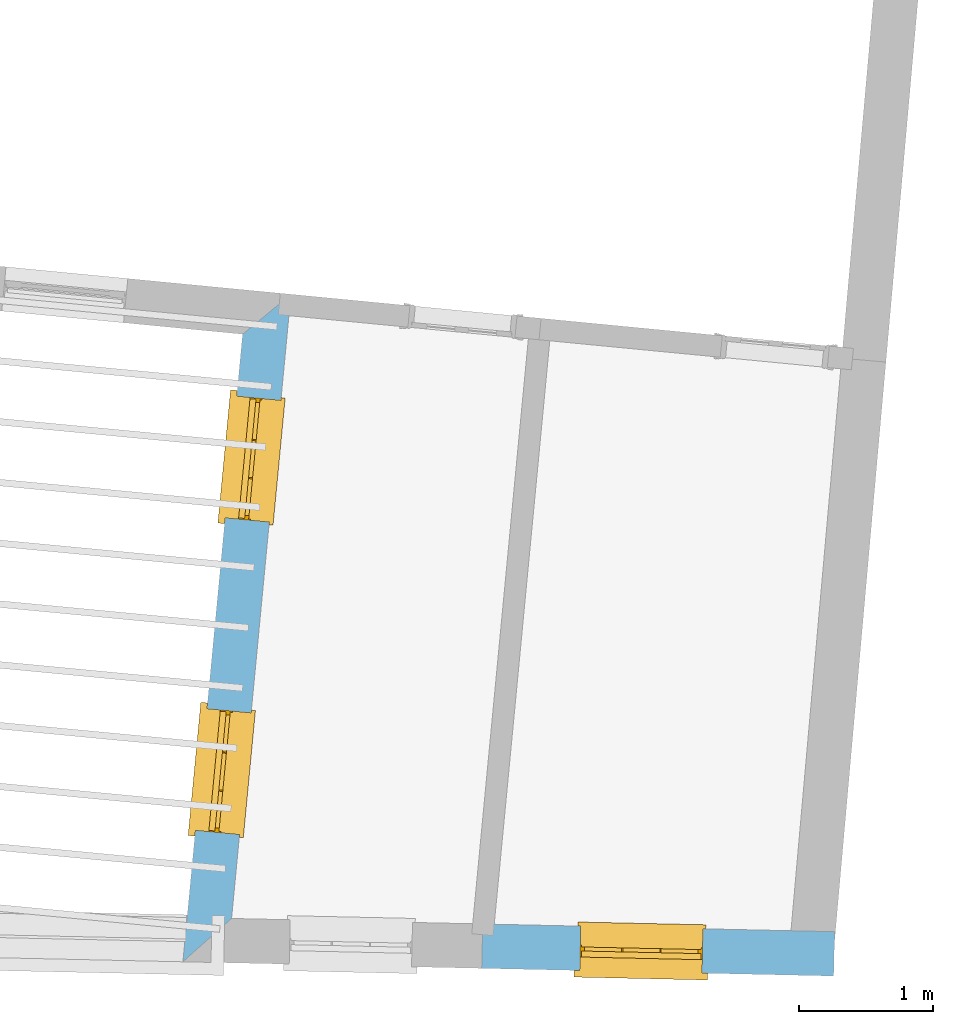
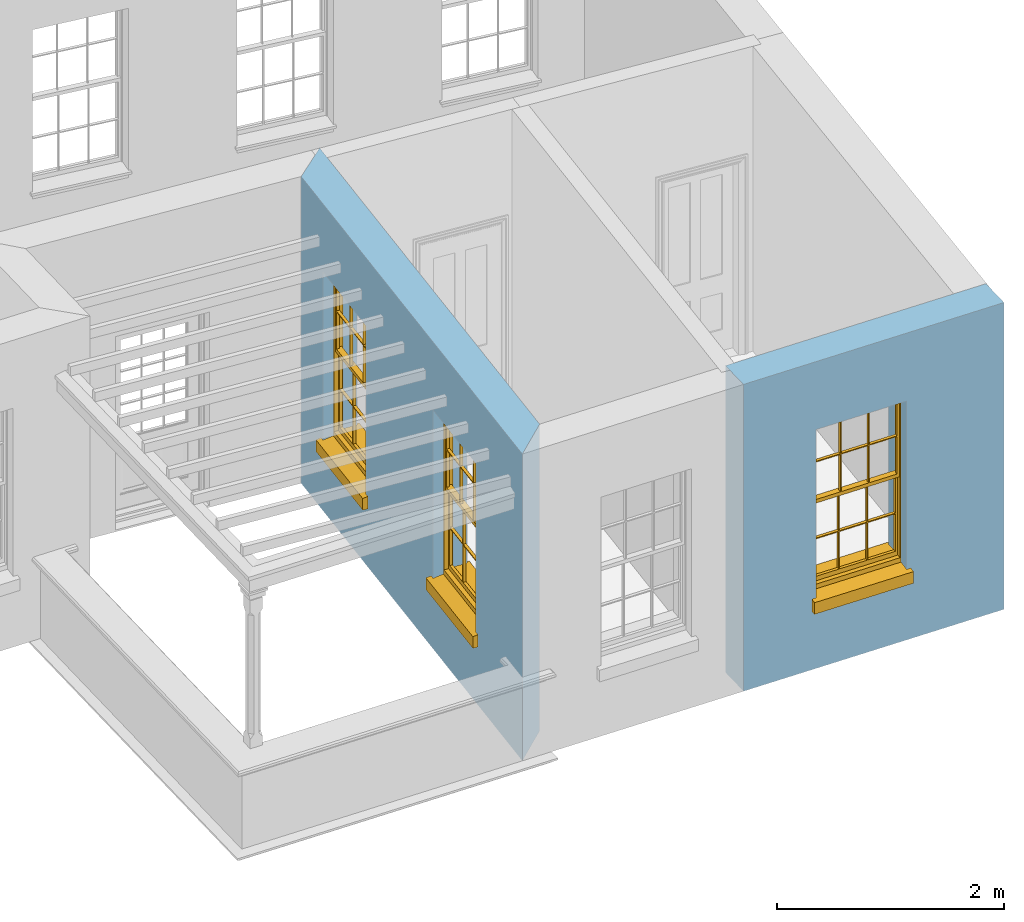
# One storey, part 5 of 12: 3 windows, 3 openings, plus 2 elements that do not belong to this part.
"""IFC2X3 building model written with IfcOpenShell, lengths in metres."""

from ifc_helpers import new_model, si_unit, frame, origin, place, context, subcontext, project, spatial, polyline, outline, extrude, faceted_brep, material, layer, layer_set, layer_usage, element, fill, save


model = new_model("IFC2X3")

# Units and contexts
model_context = context("Model", 3, world=origin())
body_context = subcontext(model_context, "Body", "Model", "MODEL_VIEW")
ifc_project = project(units=[si_unit("PLANEANGLEUNIT", "RADIAN"), si_unit("MASSUNIT", "GRAM", prefix="KILO"), si_unit("FORCEUNIT", "NEWTON", prefix="KILO"), si_unit("LENGTHUNIT", "METRE")], contexts=[model_context])

# Site, building, storey
site_placement = place(None, origin())
site = spatial("IfcSite", under=ifc_project, at=site_placement, CompositionType="ELEMENT")
building_placement = place(None, origin())
building = spatial("IfcBuilding", under=site, at=building_placement, Name="Building plot-18", CompositionType="ELEMENT")
storey_placement = place(None, frame((0.0, 0.0, 6.6)))
storey = spatial("IfcBuildingStorey", under=building, at=storey_placement, Name="Floor 1", CompositionType="ELEMENT", Elevation=6.6)

# Wall, openings, windows
ifc_material = material(Name="Masonry")
ifc_layer = layer(ifc_material, 0.33, ventilated=False)
ifc_layer_set = layer_set([ifc_layer], Name="My Wall")
ifc_layer_usage = layer_usage(ifc_layer_set, "AXIS2", "NEGATIVE", 0.08)
wall_1_placement = place(storey_placement, origin())
wall_1 = element("IfcWallStandardCase", 1, at=wall_1_placement, inside=storey, material=ifc_layer_usage, Name="exterior", context=body_context, shape_type="SweptSolid", body=[
    extrude(outline(polyline([(97.2209539104425, 21.533679413678), (96.8612105097509, 21.2367803320634), (96.4170785766712, 16.5695240039888), (96.7792255874086, 16.8916819408247), (97.2209539104425, 21.533679413678)])), origin(), (0.0, 0.0, 1.0), 3.3),
])
opening_1_placement = place(storey_placement, frame((0.0, 0.0, 0.75)))
opening_1 = element("IfcOpeningElement", 2, at=opening_1_placement, cuts=wall_1, Name="Opening", ObjectType="Opening", context=body_context, shape_type="SweptSolid", body=[
    extrude(outline(polyline([(96.8173925916487, 20.776310277304), (96.7311872326308, 19.8704026462087), (97.0597031867643, 19.8391413621693), (97.1459085457821, 20.7450489932646), (96.8173925916487, 20.776310277304)])), origin(), (0.0, 0.0, 1.0), 1.82),
])
opening_2_placement = place(storey_placement, frame((0.0, 0.0, 0.75)))
opening_2 = element("IfcOpeningElement", 3, at=opening_2_placement, cuts=wall_1, Name="Opening", ObjectType="Opening", context=body_context, shape_type="SweptSolid", body=[
    extrude(outline(polyline([(96.5962370834595, 18.4522498614566), (96.5100317244417, 17.5463422303613), (96.8385476785751, 17.5150809463219), (96.924753037593, 18.4209885774172), (96.5962370834595, 18.4522498614566)])), origin(), (0.0, 0.0, 1.0), 1.82),
])
window_1_placement = place(storey_placement, frame((97.0662683144771, 20.752627486365, 0.75), z_axis=(0.0, 0.0, 1.0), x_axis=(-0.0862053590178533, -0.905907631095246, 0.0)))
window_1 = element("IfcWindow", 4, at=window_1_placement, inside=storey, Name="toilet outside window", OverallHeight=1.82, OverallWidth=0.91, context=body_context, shape_type="Brep", held_by="IfcProductRepresentation", body=[
    faceted_brep([(0.033125, -0.105, 0.975209), (0.01, -0.105, 0.975209), (0.033125, -0.105, 1.376042), (0.876875, -0.105, 0.975209), (0.876875, -0.105, 1.376042), (0.9, -0.105, 0.975209), (0.876875, -0.105, 1.386042), (0.876875, -0.105, 1.786875), (0.9, -0.105, 1.81), (0.033125, -0.105, 1.786875), (0.033125, -0.105, 1.386042), (0.01, -0.105, 1.81), (0.876875, -0.135, 1.376042), (0.876875, -0.135, 0.975209), (0.9, -0.135, 0.937083), (0.033125, -0.135, 1.786875), (0.01, -0.135, 1.81), (0.033125, -0.135, 1.386042), (0.01, -0.135, 0.937083), (0.033125, -0.135, 0.975209), (0.033125, -0.135, 1.376042), (0.876875, -0.135, 1.786875), (0.876875, -0.135, 1.386042), (0.9, -0.135, 1.81), (0.033125, -0.105, 0.937083), (0.01, -0.105, 0.937083), (0.033125, -0.105, 0.53625), (0.876875, -0.105, 0.937083), (0.876875, -0.105, 0.53625), (0.9, -0.105, 0.937083), (0.876875, -0.105, 0.52625), (0.876875, -0.105, 0.125417), (0.9, -0.105, 0.077167), (0.033125, -0.105, 0.125417), (0.033125, -0.105, 0.52625), (0.01, -0.105, 0.077167), (-0.0425, -0.25, 0.01), (-0.0425, -0.3, 0.001667), (0.0, -0.25, 0.01), (0.9525, -0.25, 0.01), (0.91, -0.25, 0.01), (0.9525, -0.3, 0.001667), (-0.02, 0.08, 0.077167), (0.0, 0.08, 0.077167), (-0.02, 0.11, 0.077167), (0.0, -0.06, 0.077167), (0.01, -0.06, 0.077167), (0.91, -0.06, 0.077167), (0.91, 0.08, 0.077167), (0.9, -0.06, 0.077167), (0.93, 0.08, 0.077167), (0.93, 0.11, 0.077167), (0.01, -0.075, 0.975209), (0.9, -0.075, 0.975209), (0.876875, -0.075, 0.125417), (0.876875, -0.075, 0.52625), (0.9, -0.075, 0.077167), (0.876875, -0.075, 0.53625), (0.876875, -0.075, 0.937083), (0.033125, -0.075, 0.125417), (0.01, -0.075, 0.077167), (0.033125, -0.075, 0.52625), (0.033125, -0.075, 0.937083), (0.033125, -0.075, 0.53625), (-0.02, 0.08, 0.052167), (-0.02, 0.11, 0.052167), (0.93, 0.11, 0.052167), (0.93, 0.08, 0.052167), (0.91, 0.08, 0.052167), (0.0, 0.08, 0.052167), (0.91, -0.15, 0.026667), (0.0, -0.15, 0.026667), (-0.0425, -0.3, -0.123333), (0.9525, -0.3, -0.123333), (-0.0425, -0.25, -0.123333), (0.9525, -0.25, -0.123333), (0.01, -0.06, 1.81), (0.9, -0.06, 1.81), (0.0, -0.06, 1.82), (0.91, -0.06, 1.82), (0.01, -0.15, 0.077167), (0.9, -0.15, 0.077167), (0.592292, -0.105, 0.125417), (0.592292, -0.075, 0.125417), (0.317708, -0.075, 0.125417), (0.317708, -0.105, 0.125417), (0.592292, -0.105, 0.53625), (0.317708, -0.105, 0.53625), (0.317708, -0.105, 0.52625), (0.592292, -0.105, 0.52625), (0.592292, -0.075, 0.53625), (0.317708, -0.075, 0.53625), (0.592292, -0.135, 1.386042), (0.592292, -0.105, 1.386042), (0.317708, -0.105, 1.386042), (0.317708, -0.135, 1.386042), (0.317708, -0.135, 1.376042), (0.592292, -0.135, 1.376042), (0.317708, -0.105, 1.376042), (0.592292, -0.105, 1.376042), (0.602292, -0.135, 1.376042), (0.592292, -0.135, 0.975209), (0.602292, -0.135, 0.975209), (0.602292, -0.105, 0.975209), (0.592292, -0.105, 0.975209), (0.602292, -0.105, 1.376042), (0.602292, -0.075, 0.53625), (0.602292, -0.105, 0.53625), (0.317708, -0.075, 0.52625), (0.307708, -0.075, 0.125417), (0.307708, -0.075, 0.52625), (0.602292, -0.075, 0.52625), (0.602292, -0.075, 0.125417), (0.592292, -0.075, 0.52625), (0.307708, -0.075, 0.53625), (0.317708, -0.075, 0.937083), (0.307708, -0.075, 0.937083), (0.602292, -0.075, 0.937083), (0.592292, -0.075, 0.937083), (0.307708, -0.105, 0.52625), (0.307708, -0.105, 0.125417), (0.307708, -0.105, 0.53625), (0.307708, -0.105, 0.937083), (0.592292, -0.105, 0.937083), (0.317708, -0.105, 0.937083), (0.602292, -0.105, 0.937083), (0.602292, -0.105, 0.52625), (0.602292, -0.105, 0.125417), (0.307708, -0.135, 1.386042), (0.307708, -0.135, 1.376042), (0.307708, -0.135, 0.975209), (0.317708, -0.135, 0.975209), (0.317708, -0.135, 1.786875), (0.307708, -0.135, 1.786875), (0.602292, -0.135, 1.786875), (0.592292, -0.135, 1.786875), (0.602292, -0.135, 1.386042), (0.602292, -0.105, 1.386042), (0.307708, -0.105, 1.386042), (0.307708, -0.105, 1.786875), (0.317708, -0.105, 1.786875), (0.592292, -0.105, 1.786875), (0.602292, -0.105, 1.786875), (0.307708, -0.105, 1.376042), (0.317708, -0.105, 0.975209), (0.307708, -0.105, 0.975209), (0.91, -0.15, 1.82), (0.9, -0.15, 1.81), (0.01, -0.15, 1.81), (0.0, -0.15, 1.82), (0.91, -0.25, 0.0), (0.0, -0.25, 0.0), (0.91, 0.08, 0.0), (0.0, 0.08, 0.0)], [[[0, 1, 2]], [[3, 4, 5]], [[6, 7, 8]], [[9, 10, 11]], [[12, 13, 14]], [[15, 16, 17]], [[18, 19, 20]], [[21, 22, 23]], [[24, 25, 26]], [[27, 28, 29]], [[30, 31, 32]], [[33, 34, 35]], [[14, 27, 29]], [[25, 24, 18]], [[36, 37, 38]], [[39, 40, 41]], [[42, 43, 44]], [[45, 46, 43]], [[47, 48, 49]], [[50, 51, 48]], [[1, 0, 52]], [[5, 53, 3]], [[54, 55, 56]], [[57, 58, 53]], [[59, 60, 61]], [[62, 63, 52]], [[48, 43, 46, 49]], [[51, 44, 43, 48]], [[64, 42, 44, 65]], [[65, 44, 51, 66]], [[66, 51, 50, 67]], [[65, 66, 68, 69]], [[60, 56, 49, 46]], [[70, 71, 38, 40]], [[37, 41, 40, 38]], [[37, 72, 73, 41]], [[74, 75, 73, 72]], [[8, 11, 76, 77]], [[76, 78, 79, 77]], [[32, 35, 80, 81]], [[81, 80, 71, 70]], [[82, 83, 84, 85]], [[86, 87, 88, 89]], [[86, 90, 91, 87]], [[92, 93, 94, 95]], [[92, 95, 96, 97]], [[96, 98, 99, 97]], [[100, 97, 101, 102]], [[103, 104, 99, 105]], [[97, 99, 104, 101]], [[102, 103, 105, 100]], [[28, 57, 106, 107]], [[108, 84, 109, 110]], [[111, 112, 83, 113]], [[114, 110, 61, 63]], [[90, 113, 108, 91]], [[115, 91, 114, 116]], [[117, 106, 90, 118]], [[111, 106, 57, 55]], [[119, 110, 109, 120]], [[34, 61, 110, 119]], [[89, 113, 83, 82]], [[88, 108, 113, 89]], [[85, 84, 108, 88]], [[121, 114, 63, 26]], [[122, 116, 114, 121]], [[123, 118, 90, 86]], [[87, 91, 115, 124]], [[107, 106, 117, 125]], [[126, 111, 55, 30]], [[127, 112, 111, 126]], [[126, 30, 28, 107]], [[88, 119, 120, 85]], [[126, 89, 82, 127]], [[125, 123, 86, 107]], [[121, 26, 34, 119]], [[124, 122, 121, 87]], [[128, 17, 20, 129]], [[96, 129, 130, 131]], [[132, 133, 128, 95]], [[134, 135, 92, 136]], [[100, 12, 22, 136]], [[137, 6, 4, 105]], [[94, 138, 139, 140]], [[137, 93, 141, 142]], [[99, 98, 94, 93]], [[143, 2, 10, 138]], [[144, 145, 143, 98]], [[129, 143, 145, 130]], [[20, 2, 143, 129]], [[131, 144, 98, 96]], [[128, 138, 10, 17]], [[133, 139, 138, 128]], [[135, 141, 93, 92]], [[95, 94, 140, 132]], [[22, 6, 137, 136]], [[136, 137, 142, 134]], [[100, 105, 4, 12]], [[107, 86, 89, 126]], [[106, 111, 113, 90]], [[91, 108, 110, 114]], [[87, 121, 119, 88]], [[97, 100, 136, 92]], [[129, 96, 95, 128]], [[98, 143, 138, 94]], [[105, 99, 93, 137]], [[131, 101, 104, 144]], [[124, 115, 118, 123]], [[132, 140, 141, 135]], [[120, 109, 59, 33]], [[15, 9, 139, 133]], [[134, 142, 7, 21]], [[31, 54, 112, 127]], [[36, 74, 72, 37]], [[39, 41, 73, 75]], [[18, 14, 101, 131]], [[23, 16, 132, 135]], [[83, 56, 60, 84]], [[52, 53, 118, 115]], [[53, 52, 144, 104]], [[11, 8, 141, 140]], [[14, 18, 124, 123]], [[2, 1, 11, 10]], [[8, 5, 4, 6]], [[57, 53, 56, 55]], [[60, 52, 63, 61]], [[26, 25, 35, 34]], [[32, 29, 28, 30]], [[14, 23, 22, 12]], [[18, 20, 17, 16]], [[19, 0, 2, 20]], [[17, 10, 9, 15]], [[12, 4, 3, 13]], [[21, 7, 6, 22]], [[27, 58, 57, 28]], [[30, 55, 54, 31]], [[33, 59, 61, 34]], [[26, 63, 62, 24]], [[5, 8, 77, 53]], [[76, 11, 1, 52]], [[46, 45, 78, 76]], [[49, 77, 79, 47]], [[70, 146, 147, 81]], [[71, 80, 148, 149]], [[19, 130, 145, 0]], [[102, 13, 3, 103]], [[116, 122, 24, 62]], [[29, 32, 81, 14]], [[80, 35, 25, 18]], [[60, 46, 76, 52]], [[77, 49, 56, 53]], [[23, 14, 81, 147]], [[16, 148, 80, 18]], [[35, 85, 120]], [[120, 33, 35]], [[127, 82, 32]], [[32, 31, 127]], [[32, 82, 85, 35]], [[102, 101, 14]], [[14, 13, 102]], [[18, 131, 130]], [[130, 19, 18]], [[134, 21, 23]], [[23, 135, 134]], [[16, 15, 133]], [[133, 132, 16]], [[11, 140, 139]], [[139, 9, 11]], [[142, 141, 8]], [[8, 7, 142]], [[23, 147, 148, 16]], [[146, 149, 148, 147]], [[52, 115, 116]], [[116, 62, 52]], [[118, 53, 117]], [[58, 117, 53]], [[27, 125, 117, 58]], [[56, 83, 112]], [[112, 54, 56]], [[109, 84, 60]], [[60, 59, 109]], [[125, 27, 14]], [[14, 123, 125]], [[122, 124, 18]], [[18, 24, 122]], [[145, 144, 52]], [[52, 0, 145]], [[103, 3, 53]], [[53, 104, 103]], [[79, 78, 149, 146]], [[78, 45, 71, 149]], [[146, 70, 47, 79]], [[150, 75, 74, 151]], [[68, 66, 67]], [[48, 68, 67, 50]], [[69, 64, 65]], [[42, 64, 69, 43]], [[69, 68, 152, 153]], [[70, 68, 48, 47]], [[150, 152, 68, 70]], [[43, 69, 71, 45]], [[69, 153, 151, 71]], [[152, 150, 151, 153]], [[38, 151, 74, 36]], [[71, 151, 38]], [[39, 75, 150, 40]], [[40, 150, 70]]]),
])
fill(opening_1, window_1)
window_2_placement = place(storey_placement, frame((96.8451128062879, 18.4285670705176, 0.75), z_axis=(0.0, 0.0, 1.0), x_axis=(-0.0862053590178533, -0.905907631095246, 0.0)))
window_2 = element("IfcWindow", 5, at=window_2_placement, inside=storey, Name="toilet outside window", OverallHeight=1.82, OverallWidth=0.91, context=body_context, shape_type="Brep", held_by="IfcProductRepresentation", body=[
    faceted_brep([(0.033125, -0.105, 0.975209), (0.01, -0.105, 0.975209), (0.033125, -0.105, 1.376042), (0.876875, -0.105, 0.975209), (0.876875, -0.105, 1.376042), (0.9, -0.105, 0.975209), (0.876875, -0.105, 1.386042), (0.876875, -0.105, 1.786875), (0.9, -0.105, 1.81), (0.033125, -0.105, 1.786875), (0.033125, -0.105, 1.386042), (0.01, -0.105, 1.81), (0.876875, -0.135, 1.376042), (0.876875, -0.135, 0.975209), (0.9, -0.135, 0.937083), (0.033125, -0.135, 1.786875), (0.01, -0.135, 1.81), (0.033125, -0.135, 1.386042), (0.01, -0.135, 0.937083), (0.033125, -0.135, 0.975209), (0.033125, -0.135, 1.376042), (0.876875, -0.135, 1.786875), (0.876875, -0.135, 1.386042), (0.9, -0.135, 1.81), (0.033125, -0.105, 0.937083), (0.01, -0.105, 0.937083), (0.033125, -0.105, 0.53625), (0.876875, -0.105, 0.937083), (0.876875, -0.105, 0.53625), (0.9, -0.105, 0.937083), (0.876875, -0.105, 0.52625), (0.876875, -0.105, 0.125417), (0.9, -0.105, 0.077167), (0.033125, -0.105, 0.125417), (0.033125, -0.105, 0.52625), (0.01, -0.105, 0.077167), (-0.0425, -0.25, 0.01), (-0.0425, -0.3, 0.001667), (0.0, -0.25, 0.01), (0.9525, -0.25, 0.01), (0.91, -0.25, 0.01), (0.9525, -0.3, 0.001667), (-0.02, 0.08, 0.077167), (0.0, 0.08, 0.077167), (-0.02, 0.11, 0.077167), (0.0, -0.06, 0.077167), (0.01, -0.06, 0.077167), (0.91, -0.06, 0.077167), (0.91, 0.08, 0.077167), (0.9, -0.06, 0.077167), (0.93, 0.08, 0.077167), (0.93, 0.11, 0.077167), (0.01, -0.075, 0.975209), (0.9, -0.075, 0.975209), (0.876875, -0.075, 0.125417), (0.876875, -0.075, 0.52625), (0.9, -0.075, 0.077167), (0.876875, -0.075, 0.53625), (0.876875, -0.075, 0.937083), (0.033125, -0.075, 0.125417), (0.01, -0.075, 0.077167), (0.033125, -0.075, 0.52625), (0.033125, -0.075, 0.937083), (0.033125, -0.075, 0.53625), (-0.02, 0.08, 0.052167), (-0.02, 0.11, 0.052167), (0.93, 0.11, 0.052167), (0.93, 0.08, 0.052167), (0.91, 0.08, 0.052167), (0.0, 0.08, 0.052167), (0.91, -0.15, 0.026667), (0.0, -0.15, 0.026667), (-0.0425, -0.3, -0.123333), (0.9525, -0.3, -0.123333), (-0.0425, -0.25, -0.123333), (0.9525, -0.25, -0.123333), (0.01, -0.06, 1.81), (0.9, -0.06, 1.81), (0.0, -0.06, 1.82), (0.91, -0.06, 1.82), (0.01, -0.15, 0.077167), (0.9, -0.15, 0.077167), (0.592292, -0.105, 0.125417), (0.592292, -0.075, 0.125417), (0.317708, -0.075, 0.125417), (0.317708, -0.105, 0.125417), (0.592292, -0.105, 0.53625), (0.317708, -0.105, 0.53625), (0.317708, -0.105, 0.52625), (0.592292, -0.105, 0.52625), (0.592292, -0.075, 0.53625), (0.317708, -0.075, 0.53625), (0.592292, -0.135, 1.386042), (0.592292, -0.105, 1.386042), (0.317708, -0.105, 1.386042), (0.317708, -0.135, 1.386042), (0.317708, -0.135, 1.376042), (0.592292, -0.135, 1.376042), (0.317708, -0.105, 1.376042), (0.592292, -0.105, 1.376042), (0.602292, -0.135, 1.376042), (0.592292, -0.135, 0.975209), (0.602292, -0.135, 0.975209), (0.602292, -0.105, 0.975209), (0.592292, -0.105, 0.975209), (0.602292, -0.105, 1.376042), (0.602292, -0.075, 0.53625), (0.602292, -0.105, 0.53625), (0.317708, -0.075, 0.52625), (0.307708, -0.075, 0.125417), (0.307708, -0.075, 0.52625), (0.602292, -0.075, 0.52625), (0.602292, -0.075, 0.125417), (0.592292, -0.075, 0.52625), (0.307708, -0.075, 0.53625), (0.317708, -0.075, 0.937083), (0.307708, -0.075, 0.937083), (0.602292, -0.075, 0.937083), (0.592292, -0.075, 0.937083), (0.307708, -0.105, 0.52625), (0.307708, -0.105, 0.125417), (0.307708, -0.105, 0.53625), (0.307708, -0.105, 0.937083), (0.592292, -0.105, 0.937083), (0.317708, -0.105, 0.937083), (0.602292, -0.105, 0.937083), (0.602292, -0.105, 0.52625), (0.602292, -0.105, 0.125417), (0.307708, -0.135, 1.386042), (0.307708, -0.135, 1.376042), (0.307708, -0.135, 0.975209), (0.317708, -0.135, 0.975209), (0.317708, -0.135, 1.786875), (0.307708, -0.135, 1.786875), (0.602292, -0.135, 1.786875), (0.592292, -0.135, 1.786875), (0.602292, -0.135, 1.386042), (0.602292, -0.105, 1.386042), (0.307708, -0.105, 1.386042), (0.307708, -0.105, 1.786875), (0.317708, -0.105, 1.786875), (0.592292, -0.105, 1.786875), (0.602292, -0.105, 1.786875), (0.307708, -0.105, 1.376042), (0.317708, -0.105, 0.975209), (0.307708, -0.105, 0.975209), (0.91, -0.15, 1.82), (0.9, -0.15, 1.81), (0.01, -0.15, 1.81), (0.0, -0.15, 1.82), (0.91, -0.25, 0.0), (0.0, -0.25, 0.0), (0.91, 0.08, 0.0), (0.0, 0.08, 0.0)], [[[0, 1, 2]], [[3, 4, 5]], [[6, 7, 8]], [[9, 10, 11]], [[12, 13, 14]], [[15, 16, 17]], [[18, 19, 20]], [[21, 22, 23]], [[24, 25, 26]], [[27, 28, 29]], [[30, 31, 32]], [[33, 34, 35]], [[14, 27, 29]], [[25, 24, 18]], [[36, 37, 38]], [[39, 40, 41]], [[42, 43, 44]], [[45, 46, 43]], [[47, 48, 49]], [[50, 51, 48]], [[1, 0, 52]], [[5, 53, 3]], [[54, 55, 56]], [[57, 58, 53]], [[59, 60, 61]], [[62, 63, 52]], [[48, 43, 46, 49]], [[51, 44, 43, 48]], [[64, 42, 44, 65]], [[65, 44, 51, 66]], [[66, 51, 50, 67]], [[65, 66, 68, 69]], [[60, 56, 49, 46]], [[70, 71, 38, 40]], [[37, 41, 40, 38]], [[37, 72, 73, 41]], [[74, 75, 73, 72]], [[8, 11, 76, 77]], [[76, 78, 79, 77]], [[32, 35, 80, 81]], [[81, 80, 71, 70]], [[82, 83, 84, 85]], [[86, 87, 88, 89]], [[86, 90, 91, 87]], [[92, 93, 94, 95]], [[92, 95, 96, 97]], [[96, 98, 99, 97]], [[100, 97, 101, 102]], [[103, 104, 99, 105]], [[97, 99, 104, 101]], [[102, 103, 105, 100]], [[28, 57, 106, 107]], [[108, 84, 109, 110]], [[111, 112, 83, 113]], [[114, 110, 61, 63]], [[90, 113, 108, 91]], [[115, 91, 114, 116]], [[117, 106, 90, 118]], [[111, 106, 57, 55]], [[119, 110, 109, 120]], [[34, 61, 110, 119]], [[89, 113, 83, 82]], [[88, 108, 113, 89]], [[85, 84, 108, 88]], [[121, 114, 63, 26]], [[122, 116, 114, 121]], [[123, 118, 90, 86]], [[87, 91, 115, 124]], [[107, 106, 117, 125]], [[126, 111, 55, 30]], [[127, 112, 111, 126]], [[126, 30, 28, 107]], [[88, 119, 120, 85]], [[126, 89, 82, 127]], [[125, 123, 86, 107]], [[121, 26, 34, 119]], [[124, 122, 121, 87]], [[128, 17, 20, 129]], [[96, 129, 130, 131]], [[132, 133, 128, 95]], [[134, 135, 92, 136]], [[100, 12, 22, 136]], [[137, 6, 4, 105]], [[94, 138, 139, 140]], [[137, 93, 141, 142]], [[99, 98, 94, 93]], [[143, 2, 10, 138]], [[144, 145, 143, 98]], [[129, 143, 145, 130]], [[20, 2, 143, 129]], [[131, 144, 98, 96]], [[128, 138, 10, 17]], [[133, 139, 138, 128]], [[135, 141, 93, 92]], [[95, 94, 140, 132]], [[22, 6, 137, 136]], [[136, 137, 142, 134]], [[100, 105, 4, 12]], [[107, 86, 89, 126]], [[106, 111, 113, 90]], [[91, 108, 110, 114]], [[87, 121, 119, 88]], [[97, 100, 136, 92]], [[129, 96, 95, 128]], [[98, 143, 138, 94]], [[105, 99, 93, 137]], [[131, 101, 104, 144]], [[124, 115, 118, 123]], [[132, 140, 141, 135]], [[120, 109, 59, 33]], [[15, 9, 139, 133]], [[134, 142, 7, 21]], [[31, 54, 112, 127]], [[36, 74, 72, 37]], [[39, 41, 73, 75]], [[18, 14, 101, 131]], [[23, 16, 132, 135]], [[83, 56, 60, 84]], [[52, 53, 118, 115]], [[53, 52, 144, 104]], [[11, 8, 141, 140]], [[14, 18, 124, 123]], [[2, 1, 11, 10]], [[8, 5, 4, 6]], [[57, 53, 56, 55]], [[60, 52, 63, 61]], [[26, 25, 35, 34]], [[32, 29, 28, 30]], [[14, 23, 22, 12]], [[18, 20, 17, 16]], [[19, 0, 2, 20]], [[17, 10, 9, 15]], [[12, 4, 3, 13]], [[21, 7, 6, 22]], [[27, 58, 57, 28]], [[30, 55, 54, 31]], [[33, 59, 61, 34]], [[26, 63, 62, 24]], [[5, 8, 77, 53]], [[76, 11, 1, 52]], [[46, 45, 78, 76]], [[49, 77, 79, 47]], [[70, 146, 147, 81]], [[71, 80, 148, 149]], [[19, 130, 145, 0]], [[102, 13, 3, 103]], [[116, 122, 24, 62]], [[29, 32, 81, 14]], [[80, 35, 25, 18]], [[60, 46, 76, 52]], [[77, 49, 56, 53]], [[23, 14, 81, 147]], [[16, 148, 80, 18]], [[35, 85, 120]], [[120, 33, 35]], [[127, 82, 32]], [[32, 31, 127]], [[32, 82, 85, 35]], [[102, 101, 14]], [[14, 13, 102]], [[18, 131, 130]], [[130, 19, 18]], [[134, 21, 23]], [[23, 135, 134]], [[16, 15, 133]], [[133, 132, 16]], [[11, 140, 139]], [[139, 9, 11]], [[142, 141, 8]], [[8, 7, 142]], [[23, 147, 148, 16]], [[146, 149, 148, 147]], [[52, 115, 116]], [[116, 62, 52]], [[118, 53, 117]], [[58, 117, 53]], [[27, 125, 117, 58]], [[56, 83, 112]], [[112, 54, 56]], [[109, 84, 60]], [[60, 59, 109]], [[125, 27, 14]], [[14, 123, 125]], [[122, 124, 18]], [[18, 24, 122]], [[145, 144, 52]], [[52, 0, 145]], [[103, 3, 53]], [[53, 104, 103]], [[79, 78, 149, 146]], [[78, 45, 71, 149]], [[146, 70, 47, 79]], [[150, 75, 74, 151]], [[68, 66, 67]], [[48, 68, 67, 50]], [[69, 64, 65]], [[42, 64, 69, 43]], [[69, 68, 152, 153]], [[70, 68, 48, 47]], [[150, 152, 68, 70]], [[43, 69, 71, 45]], [[69, 153, 151, 71]], [[152, 150, 151, 153]], [[38, 151, 74, 36]], [[71, 151, 38]], [[39, 75, 150, 40]], [[40, 150, 70]]]),
])
fill(opening_2, window_2)

# Wall, opening, window
wall_2_placement = place(storey_placement, origin())
wall_2 = element("IfcWallStandardCase", 6, at=wall_2_placement, inside=storey, material=ifc_layer_usage, Name="exterior", context=body_context, shape_type="SweptSolid", body=[
    extrude(outline(polyline([(98.6465862114736, 16.8508384624622), (98.6393700771944, 16.5209173697657), (101.256865456868, 16.463666716343), (101.264081591148, 16.7935878090395), (98.6465862114736, 16.8508384624622)])), origin(), (0.0, 0.0, 1.0), 3.3),
])
opening_3_placement = place(storey_placement, frame((0.0, 0.0, 0.75)))
opening_3 = element("IfcOpeningElement", 7, at=opening_3_placement, cuts=wall_2, Name="Opening", ObjectType="Opening", context=body_context, shape_type="SweptSolid", body=[
    extrude(outline(polyline([(99.3682564525951, 16.5049749457268), (100.278038859728, 16.4850759087752), (100.285254994007, 16.8149970014717), (99.3754725868743, 16.8348960384233), (99.3682564525951, 16.5049749457268)])), origin(), (0.0, 0.0, 1.0), 1.82),
])
window_3_placement = place(storey_placement, frame((99.3737232209884, 16.7549151674666, 0.75), z_axis=(0.0, 0.0, 1.0), x_axis=(0.909782407132823, -0.019899036951621, 0.0)))
window_3 = element("IfcWindow", 8, at=window_3_placement, inside=storey, Name="toilet outside window", OverallHeight=1.82, OverallWidth=0.91, context=body_context, shape_type="Brep", held_by="IfcProductRepresentation", body=[
    faceted_brep([(0.033125, -0.105, 0.975209), (0.01, -0.105, 0.975209), (0.033125, -0.105, 1.376042), (0.876875, -0.105, 0.975209), (0.876875, -0.105, 1.376042), (0.9, -0.105, 0.975209), (0.876875, -0.105, 1.386042), (0.876875, -0.105, 1.786875), (0.9, -0.105, 1.81), (0.033125, -0.105, 1.786875), (0.033125, -0.105, 1.386042), (0.01, -0.105, 1.81), (0.876875, -0.135, 1.376042), (0.876875, -0.135, 0.975209), (0.9, -0.135, 0.937083), (0.033125, -0.135, 1.786875), (0.01, -0.135, 1.81), (0.033125, -0.135, 1.386042), (0.01, -0.135, 0.937083), (0.033125, -0.135, 0.975209), (0.033125, -0.135, 1.376042), (0.876875, -0.135, 1.786875), (0.876875, -0.135, 1.386042), (0.9, -0.135, 1.81), (0.033125, -0.105, 0.937083), (0.01, -0.105, 0.937083), (0.033125, -0.105, 0.53625), (0.876875, -0.105, 0.937083), (0.876875, -0.105, 0.53625), (0.9, -0.105, 0.937083), (0.876875, -0.105, 0.52625), (0.876875, -0.105, 0.125417), (0.9, -0.105, 0.077167), (0.033125, -0.105, 0.125417), (0.033125, -0.105, 0.52625), (0.01, -0.105, 0.077167), (-0.0425, -0.25, 0.01), (-0.0425, -0.3, 0.001667), (0.0, -0.25, 0.01), (0.9525, -0.25, 0.01), (0.91, -0.25, 0.01), (0.9525, -0.3, 0.001667), (-0.02, 0.08, 0.077167), (0.0, 0.08, 0.077167), (-0.02, 0.11, 0.077167), (0.0, -0.06, 0.077167), (0.01, -0.06, 0.077167), (0.91, -0.06, 0.077167), (0.91, 0.08, 0.077167), (0.9, -0.06, 0.077167), (0.93, 0.08, 0.077167), (0.93, 0.11, 0.077167), (0.01, -0.075, 0.975209), (0.9, -0.075, 0.975209), (0.876875, -0.075, 0.125417), (0.876875, -0.075, 0.52625), (0.9, -0.075, 0.077167), (0.876875, -0.075, 0.53625), (0.876875, -0.075, 0.937083), (0.033125, -0.075, 0.125417), (0.01, -0.075, 0.077167), (0.033125, -0.075, 0.52625), (0.033125, -0.075, 0.937083), (0.033125, -0.075, 0.53625), (-0.02, 0.08, 0.052167), (-0.02, 0.11, 0.052167), (0.93, 0.11, 0.052167), (0.93, 0.08, 0.052167), (0.91, 0.08, 0.052167), (0.0, 0.08, 0.052167), (0.91, -0.15, 0.026667), (0.0, -0.15, 0.026667), (-0.0425, -0.3, -0.123333), (0.9525, -0.3, -0.123333), (-0.0425, -0.25, -0.123333), (0.9525, -0.25, -0.123333), (0.01, -0.06, 1.81), (0.9, -0.06, 1.81), (0.0, -0.06, 1.82), (0.91, -0.06, 1.82), (0.01, -0.15, 0.077167), (0.9, -0.15, 0.077167), (0.592292, -0.105, 0.125417), (0.592292, -0.075, 0.125417), (0.317708, -0.075, 0.125417), (0.317708, -0.105, 0.125417), (0.592292, -0.105, 0.53625), (0.317708, -0.105, 0.53625), (0.317708, -0.105, 0.52625), (0.592292, -0.105, 0.52625), (0.592292, -0.075, 0.53625), (0.317708, -0.075, 0.53625), (0.592292, -0.135, 1.386042), (0.592292, -0.105, 1.386042), (0.317708, -0.105, 1.386042), (0.317708, -0.135, 1.386042), (0.317708, -0.135, 1.376042), (0.592292, -0.135, 1.376042), (0.317708, -0.105, 1.376042), (0.592292, -0.105, 1.376042), (0.602292, -0.135, 1.376042), (0.592292, -0.135, 0.975209), (0.602292, -0.135, 0.975209), (0.602292, -0.105, 0.975209), (0.592292, -0.105, 0.975209), (0.602292, -0.105, 1.376042), (0.602292, -0.075, 0.53625), (0.602292, -0.105, 0.53625), (0.317708, -0.075, 0.52625), (0.307708, -0.075, 0.125417), (0.307708, -0.075, 0.52625), (0.602292, -0.075, 0.52625), (0.602292, -0.075, 0.125417), (0.592292, -0.075, 0.52625), (0.307708, -0.075, 0.53625), (0.317708, -0.075, 0.937083), (0.307708, -0.075, 0.937083), (0.602292, -0.075, 0.937083), (0.592292, -0.075, 0.937083), (0.307708, -0.105, 0.52625), (0.307708, -0.105, 0.125417), (0.307708, -0.105, 0.53625), (0.307708, -0.105, 0.937083), (0.592292, -0.105, 0.937083), (0.317708, -0.105, 0.937083), (0.602292, -0.105, 0.937083), (0.602292, -0.105, 0.52625), (0.602292, -0.105, 0.125417), (0.307708, -0.135, 1.386042), (0.307708, -0.135, 1.376042), (0.307708, -0.135, 0.975209), (0.317708, -0.135, 0.975209), (0.317708, -0.135, 1.786875), (0.307708, -0.135, 1.786875), (0.602292, -0.135, 1.786875), (0.592292, -0.135, 1.786875), (0.602292, -0.135, 1.386042), (0.602292, -0.105, 1.386042), (0.307708, -0.105, 1.386042), (0.307708, -0.105, 1.786875), (0.317708, -0.105, 1.786875), (0.592292, -0.105, 1.786875), (0.602292, -0.105, 1.786875), (0.307708, -0.105, 1.376042), (0.317708, -0.105, 0.975209), (0.307708, -0.105, 0.975209), (0.91, -0.15, 1.82), (0.9, -0.15, 1.81), (0.01, -0.15, 1.81), (0.0, -0.15, 1.82), (0.91, -0.25, 0.0), (0.0, -0.25, 0.0), (0.91, 0.08, 0.0), (0.0, 0.08, 0.0)], [[[0, 1, 2]], [[3, 4, 5]], [[6, 7, 8]], [[9, 10, 11]], [[12, 13, 14]], [[15, 16, 17]], [[18, 19, 20]], [[21, 22, 23]], [[24, 25, 26]], [[27, 28, 29]], [[30, 31, 32]], [[33, 34, 35]], [[14, 27, 29]], [[25, 24, 18]], [[36, 37, 38]], [[39, 40, 41]], [[42, 43, 44]], [[45, 46, 43]], [[47, 48, 49]], [[50, 51, 48]], [[1, 0, 52]], [[5, 53, 3]], [[54, 55, 56]], [[57, 58, 53]], [[59, 60, 61]], [[62, 63, 52]], [[48, 43, 46, 49]], [[51, 44, 43, 48]], [[64, 42, 44, 65]], [[65, 44, 51, 66]], [[66, 51, 50, 67]], [[65, 66, 68, 69]], [[60, 56, 49, 46]], [[70, 71, 38, 40]], [[37, 41, 40, 38]], [[37, 72, 73, 41]], [[74, 75, 73, 72]], [[8, 11, 76, 77]], [[76, 78, 79, 77]], [[32, 35, 80, 81]], [[81, 80, 71, 70]], [[82, 83, 84, 85]], [[86, 87, 88, 89]], [[86, 90, 91, 87]], [[92, 93, 94, 95]], [[92, 95, 96, 97]], [[96, 98, 99, 97]], [[100, 97, 101, 102]], [[103, 104, 99, 105]], [[97, 99, 104, 101]], [[102, 103, 105, 100]], [[28, 57, 106, 107]], [[108, 84, 109, 110]], [[111, 112, 83, 113]], [[114, 110, 61, 63]], [[90, 113, 108, 91]], [[115, 91, 114, 116]], [[117, 106, 90, 118]], [[111, 106, 57, 55]], [[119, 110, 109, 120]], [[34, 61, 110, 119]], [[89, 113, 83, 82]], [[88, 108, 113, 89]], [[85, 84, 108, 88]], [[121, 114, 63, 26]], [[122, 116, 114, 121]], [[123, 118, 90, 86]], [[87, 91, 115, 124]], [[107, 106, 117, 125]], [[126, 111, 55, 30]], [[127, 112, 111, 126]], [[126, 30, 28, 107]], [[88, 119, 120, 85]], [[126, 89, 82, 127]], [[125, 123, 86, 107]], [[121, 26, 34, 119]], [[124, 122, 121, 87]], [[128, 17, 20, 129]], [[96, 129, 130, 131]], [[132, 133, 128, 95]], [[134, 135, 92, 136]], [[100, 12, 22, 136]], [[137, 6, 4, 105]], [[94, 138, 139, 140]], [[137, 93, 141, 142]], [[99, 98, 94, 93]], [[143, 2, 10, 138]], [[144, 145, 143, 98]], [[129, 143, 145, 130]], [[20, 2, 143, 129]], [[131, 144, 98, 96]], [[128, 138, 10, 17]], [[133, 139, 138, 128]], [[135, 141, 93, 92]], [[95, 94, 140, 132]], [[22, 6, 137, 136]], [[136, 137, 142, 134]], [[100, 105, 4, 12]], [[107, 86, 89, 126]], [[106, 111, 113, 90]], [[91, 108, 110, 114]], [[87, 121, 119, 88]], [[97, 100, 136, 92]], [[129, 96, 95, 128]], [[98, 143, 138, 94]], [[105, 99, 93, 137]], [[131, 101, 104, 144]], [[124, 115, 118, 123]], [[132, 140, 141, 135]], [[120, 109, 59, 33]], [[15, 9, 139, 133]], [[134, 142, 7, 21]], [[31, 54, 112, 127]], [[36, 74, 72, 37]], [[39, 41, 73, 75]], [[18, 14, 101, 131]], [[23, 16, 132, 135]], [[83, 56, 60, 84]], [[52, 53, 118, 115]], [[53, 52, 144, 104]], [[11, 8, 141, 140]], [[14, 18, 124, 123]], [[2, 1, 11, 10]], [[8, 5, 4, 6]], [[57, 53, 56, 55]], [[60, 52, 63, 61]], [[26, 25, 35, 34]], [[32, 29, 28, 30]], [[14, 23, 22, 12]], [[18, 20, 17, 16]], [[19, 0, 2, 20]], [[17, 10, 9, 15]], [[12, 4, 3, 13]], [[21, 7, 6, 22]], [[27, 58, 57, 28]], [[30, 55, 54, 31]], [[33, 59, 61, 34]], [[26, 63, 62, 24]], [[5, 8, 77, 53]], [[76, 11, 1, 52]], [[46, 45, 78, 76]], [[49, 77, 79, 47]], [[70, 146, 147, 81]], [[71, 80, 148, 149]], [[19, 130, 145, 0]], [[102, 13, 3, 103]], [[116, 122, 24, 62]], [[29, 32, 81, 14]], [[80, 35, 25, 18]], [[60, 46, 76, 52]], [[77, 49, 56, 53]], [[23, 14, 81, 147]], [[16, 148, 80, 18]], [[35, 85, 120]], [[120, 33, 35]], [[127, 82, 32]], [[32, 31, 127]], [[32, 82, 85, 35]], [[102, 101, 14]], [[14, 13, 102]], [[18, 131, 130]], [[130, 19, 18]], [[134, 21, 23]], [[23, 135, 134]], [[16, 15, 133]], [[133, 132, 16]], [[11, 140, 139]], [[139, 9, 11]], [[142, 141, 8]], [[8, 7, 142]], [[23, 147, 148, 16]], [[146, 149, 148, 147]], [[52, 115, 116]], [[116, 62, 52]], [[118, 53, 117]], [[58, 117, 53]], [[27, 125, 117, 58]], [[56, 83, 112]], [[112, 54, 56]], [[109, 84, 60]], [[60, 59, 109]], [[125, 27, 14]], [[14, 123, 125]], [[122, 124, 18]], [[18, 24, 122]], [[145, 144, 52]], [[52, 0, 145]], [[103, 3, 53]], [[53, 104, 103]], [[79, 78, 149, 146]], [[78, 45, 71, 149]], [[146, 70, 47, 79]], [[150, 75, 74, 151]], [[68, 66, 67]], [[48, 68, 67, 50]], [[69, 64, 65]], [[42, 64, 69, 43]], [[69, 68, 152, 153]], [[70, 68, 48, 47]], [[150, 152, 68, 70]], [[43, 69, 71, 45]], [[69, 153, 151, 71]], [[152, 150, 151, 153]], [[38, 151, 74, 36]], [[71, 151, 38]], [[39, 75, 150, 40]], [[40, 150, 70]]]),
])
fill(opening_3, window_3)

save(model, "model.ifc")
